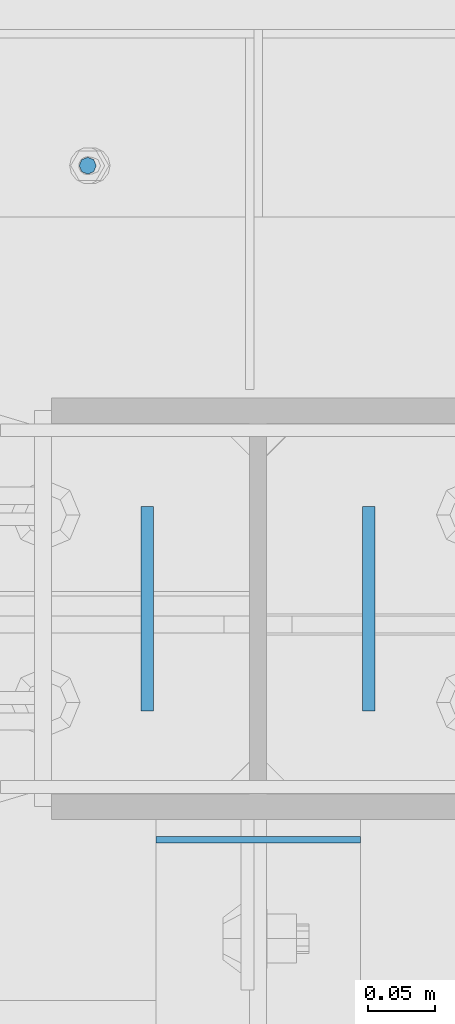
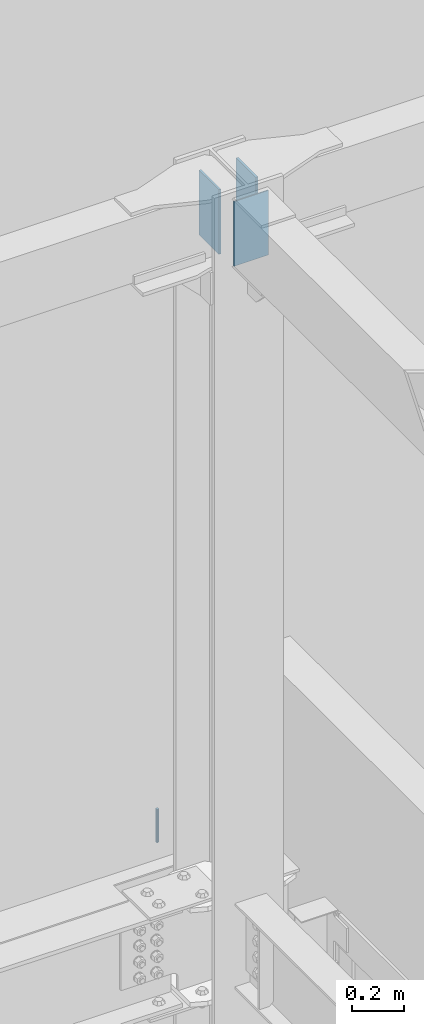
# One storey, part 588 of 1179: 4 columns, 4 elements without a shape of their own.
"""IFC2X3 building model written with IfcOpenShell, lengths in millimetres."""

import ifcopenshell
import ifcopenshell.guid

model = None  # the IFC model being written
_history = None  # IfcOwnerHistory: only IFC2X3 demands one
_inside = {}  # id of a spatial element -> (the spatial element, [elements in it])
_under = {}  # id of a project, library or spatial element -> (it, [spatial elements below it])
_declared = {}  # id of a project -> (the project, [libraries it declares])
_typed = {}  # id of a type object -> (the type object, [elements of that type])
_made_of = {}  # id of a material, layer set ... -> (it, [elements and type objects made of it])


def new_model(schema):
    """Start an empty IFC model of exactly this schema.

    Asked for "IFC4X3", IfcOpenShell would pick the latest addendum, in which some entities
    have other attributes; the version numbers below select the first issue.
    IFC2X3 requires an IfcOwnerHistory on every rooted entity: one is made here for all.
    """
    global model, _history
    if schema == "IFC4X3":
        model = ifcopenshell.file(schema_version=(4, 3, 0, 0))
    else:
        model = ifcopenshell.file(schema=schema)
    _inside.clear()
    _under.clear()
    _declared.clear()
    _typed.clear()
    _made_of.clear()
    _history = None
    if model.schema == "IFC2X3":
        org = make("IfcOrganization", Name="unknown")
        user = make(
            "IfcPersonAndOrganization",
            ThePerson=make("IfcPerson", FamilyName="unknown"),
            TheOrganization=org,
        )
        app = make(
            "IfcApplication",
            ApplicationDeveloper=org,
            Version="unknown",
            ApplicationFullName="unknown",
            ApplicationIdentifier="unknown",
        )
        _history = make(
            "IfcOwnerHistory",
            OwningUser=user,
            OwningApplication=app,
            ChangeAction="ADDED",
            CreationDate=0,
        )
    return model


def make(cls, **values):
    """One entity of the class cls with the attributes given. An attribute that is None is left unset."""
    return model.create_entity(
        cls, **{name: value for name, value in values.items() if value is not None}
    )


def rooted(cls, **values):
    """An entity with a GlobalId (a new one), such as an element, a storey or a relation."""
    return make(cls, GlobalId=ifcopenshell.guid.new(), OwnerHistory=_history, **values)


def si_unit(unit_type, name, prefix=None):
    """IfcSIUnit, for example si_unit("LENGTHUNIT", "METRE", prefix="MILLI")."""
    return make("IfcSIUnit", UnitType=unit_type, Prefix=prefix, Name=name)


def assignment(units):
    """IfcUnitAssignment: the units of a project."""
    return None if units is None else make("IfcUnitAssignment", Units=units)


def point(xyz):
    """IfcCartesianPoint."""
    return None if xyz is None else make("IfcCartesianPoint", Coordinates=xyz)


def direction(xyz):
    """IfcDirection."""
    return None if xyz is None else make("IfcDirection", DirectionRatios=xyz)


def frame(location, z_axis=None, x_axis=None):
    """IfcAxis2Placement3D, a coordinate frame: its origin and axes. An axis left out is left unset."""
    return make(
        "IfcAxis2Placement3D",
        Location=point(location),
        Axis=direction(z_axis),
        RefDirection=direction(x_axis),
    )


def origin_with_axes():
    """The frame at (0, 0, 0) with the z axis (0, 0, 1) and the x axis (1, 0, 0) written out."""
    return frame((0.0, 0.0, 0.0), z_axis=(0.0, 0.0, 1.0), x_axis=(1.0, 0.0, 0.0))


def place(relative_to, where):
    """IfcLocalPlacement: puts the frame where relative to a parent placement (None: the world)."""
    return make(
        "IfcLocalPlacement", PlacementRelTo=relative_to, RelativePlacement=where
    )


def context(
    kind, dimensions, precision=None, world=None, true_north=None, identifier=None
):
    """IfcGeometricRepresentationContext, for example the 3D "Model" context."""
    return make(
        "IfcGeometricRepresentationContext",
        ContextIdentifier=identifier,
        ContextType=kind,
        CoordinateSpaceDimension=dimensions,
        Precision=precision,
        WorldCoordinateSystem=world,
        TrueNorth=true_north,
    )


def subcontext(parent, identifier, kind, view, scale=None):
    """IfcGeometricRepresentationSubContext, for example "Body" below "Model"."""
    return make(
        "IfcGeometricRepresentationSubContext",
        ContextIdentifier=identifier,
        ContextType=kind,
        ParentContext=parent,
        TargetScale=scale,
        TargetView=view,
    )


def project(units=None, contexts=None):
    """IfcProject with its units and contexts."""
    return rooted(
        "IfcProject",
        Name="project",
        RepresentationContexts=contexts,
        UnitsInContext=assignment(units),
    )


def spatial(cls, under=None, at=None, **own):
    """A site, building, storey or space (cls), placed at a placement, below another one or the project."""
    s = rooted(cls, ObjectPlacement=at, **own)
    if under is not None:
        _under.setdefault(under.id(), (under, []))[1].append(s)
    return s


def faces_of(points, faces, orient=None, outer=None):
    """IfcFace entities. A face is a list of loops; a loop is a list of indices into points, from 0.

    orient and outer hold one flag for each loop. By default every Orientation is true, the
    first loop of a face is its IfcFaceOuterBound and the others are IfcFaceBound.
    """
    made = []
    for i, loops in enumerate(faces):
        bounds = []
        for j, loop in enumerate(loops):
            is_outer = j == 0 if outer is None else outer[i][j]
            bounds.append(
                make(
                    "IfcFaceOuterBound" if is_outer else "IfcFaceBound",
                    Bound=make("IfcPolyLoop", Polygon=[points[k] for k in loop]),
                    Orientation=True if orient is None else orient[i][j],
                )
            )
        made.append(make("IfcFace", Bounds=bounds))
    return made


def faceted_brep(points, faces, orient=None, outer=None, voids=None):
    """IfcFacetedBrep: a solid bounded by flat faces; with voids (closed shells), ...WithVoids."""
    shared = [point(p) for p in points]
    hull = make("IfcClosedShell", CfsFaces=faces_of(shared, faces, orient, outer))
    if voids is None:
        return make("IfcFacetedBrep", Outer=hull)
    return make(
        "IfcFacetedBrepWithVoids",
        Outer=hull,
        Voids=[
            make(cls, CfsFaces=faces_of(shared, fs, o, b)) for cls, fs, o, b in voids
        ],
    )


def shape(context_of_items, identifier, shape_type, items):
    """IfcShapeRepresentation: the items that make up one representation, for example the "Body"."""
    return make(
        "IfcShapeRepresentation",
        ContextOfItems=context_of_items,
        RepresentationIdentifier=identifier,
        RepresentationType=shape_type,
        Items=items,
    )


def material(Name=None, Category=None):
    """IfcMaterial."""
    return make("IfcMaterial", Name=Name, Category=Category)


def made_of(thing, what):
    """Note that an element or type object is made of a material, layer set ...; save() writes the relation."""
    if what is not None:
        _made_of.setdefault(what.id(), (what, []))[1].append(thing)
    return thing


def type_object(cls, material=None, **own):
    """A type object (cls), such as IfcWallType, which elements share."""
    return made_of(rooted(cls, **own), material)


def element(
    cls,
    number,
    at=None,
    inside=None,
    cuts=None,
    type_object=None,
    material=None,
    context=None,
    identifier="Body",
    shape_type=None,
    held_by="IfcProductDefinitionShape",
    body=None,
    shapes=None,
    **own,
):
    """One element of the class cls, such as IfcWall. Its Tag is "e" and its number.

    at: its placement. inside: the storey or other place that contains it. cuts: it is an
    opening in that element (IfcRelVoidsElement). A single representation is given by context,
    identifier, shape_type and body (its items); several are given by shapes. held_by: the class
    of the entity that holds the representations. save() writes the other relations.
    """
    e = rooted(cls, Tag="e%d" % number, ObjectPlacement=at, **own)
    if body is not None:
        shapes = [shape(context, identifier, shape_type, body)]
    if shapes is not None:
        e.Representation = make(held_by, Representations=shapes)
    if inside is not None:
        _inside.setdefault(inside.id(), (inside, []))[1].append(e)
    if cuts is not None:
        rooted(
            "IfcRelVoidsElement", RelatingBuildingElement=cuts, RelatedOpeningElement=e
        )
    if type_object is not None:
        _typed.setdefault(type_object.id(), (type_object, []))[1].append(e)
    return made_of(e, material)


def aggregate(whole, parts):
    """IfcRelAggregates: a whole, such as a stair, and the parts it consists of."""
    return rooted("IfcRelAggregates", RelatingObject=whole, RelatedObjects=parts)


def save(model, path):
    """Write the relations noted so far, then the file.

    IfcRelAggregates (storeys below a building ...), IfcRelContainedInSpatialStructure (elements
    in a storey), IfcRelDefinesByType, IfcRelAssociatesMaterial and IfcRelDeclares: one each for
    every whole, place, type object, material and project.
    """
    for whole, parts in _under.values():
        aggregate(whole, parts)
    for where, things in _inside.values():
        rooted(
            "IfcRelContainedInSpatialStructure",
            RelatedElements=things,
            RelatingStructure=where,
        )
    for kind, things in _typed.values():
        rooted("IfcRelDefinesByType", RelatedObjects=things, RelatingType=kind)
    for what, things in _made_of.values():
        rooted("IfcRelAssociatesMaterial", RelatedObjects=things, RelatingMaterial=what)
    for by, libraries in _declared.values():
        rooted("IfcRelDeclares", RelatingContext=by, RelatedDefinitions=libraries)
    model.write(path)


model = new_model("IFC2X3")

# Units and contexts
model_context = context("Model", 3, precision=1e-05, world=origin_with_axes())
body_context = subcontext(model_context, "Body", "Model", "MODEL_VIEW")
ifc_project = project(units=[si_unit("LENGTHUNIT", "METRE", prefix="MILLI"), si_unit("AREAUNIT", "SQUARE_METRE"), si_unit("VOLUMEUNIT", "CUBIC_METRE"), si_unit("MASSUNIT", "GRAM", prefix="KILO"), si_unit("TIMEUNIT", "SECOND"), si_unit("PLANEANGLEUNIT", "RADIAN"), si_unit("SOLIDANGLEUNIT", "STERADIAN"), si_unit("THERMODYNAMICTEMPERATUREUNIT", "DEGREE_CELSIUS"), si_unit("LUMINOUSINTENSITYUNIT", "LUMEN")], contexts=[model_context])

# Site, building, storey
site_placement = place(None, origin_with_axes())
site = spatial("IfcSite", under=ifc_project, at=site_placement, CompositionType="ELEMENT")
building_placement = place(site_placement, origin_with_axes())
building = spatial("IfcBuilding", under=site, at=building_placement, Name="Undefined", CompositionType="ELEMENT")
storey_placement = place(building_placement, origin_with_axes())
storey = spatial("IfcBuildingStorey", under=building, at=storey_placement, Name="Undefined", CompositionType="ELEMENT", Elevation=0.0)

# Assembly, column
assembly_1_placement = place(storey_placement, origin_with_axes())
assembly_1 = element("IfcElementAssembly", 1, at=assembly_1_placement, inside=storey, Name="BEAM", AssemblyPlace="NOTDEFINED", PredefinedType="RIGID_FRAME")
ifc_material_1 = material(Name="STEEL/A307")
column_type_1 = type_object("IfcColumnType", PredefinedType="NOTDEFINED")
column_1_placement = place(assembly_1_placement, frame((16332.2, 41529.0, 13125.45), z_axis=(0.0, 1.0, 0.0), x_axis=(0.0, 0.0, 1.0)))
column_1 = element("IfcColumn", 2, at=column_1_placement, type_object=column_type_1, material=ifc_material_1, Name="THREADED ROD", context=body_context, shape_type="Brep", body=[
    faceted_brep([(0.0, -6.34999999999854, 0.0), (0.0, -4.49012806053361, -4.49012806053452), (157.162499999999, -4.49012806053361, -4.49012806053361), (157.162499999999, -6.34999999999854, 0.0), (0.0, 0.0, -6.34999999999991), (157.162499999999, 0.0, -6.34999999999854), (0.0, 4.49012806053361, -4.49012806053452), (157.162499999999, 4.49012806053361, -4.49012806053361), (0.0, 6.34999999999854, 0.0), (157.162499999999, 6.34999999999854, 0.0), (0.0, 4.49012806053361, 4.49012806053452), (157.162499999999, 4.49012806053361, 4.49012806053361), (0.0, 0.0, 6.34999999999991), (157.162499999999, 0.0, 6.34999999999854), (0.0, -4.49012806053361, 4.49012806053452), (157.162499999999, -4.49012806053361, 4.49012806053361)], [[[0, 1, 2, 3]], [[1, 4, 5, 2]], [[4, 6, 7, 5]], [[6, 8, 9, 7]], [[8, 10, 11, 9]], [[10, 12, 13, 11]], [[12, 14, 15, 13]], [[14, 0, 3, 15]], [[5, 7, 9, 11, 13, 15, 3, 2]], [[14, 12, 10, 8, 6, 4, 1, 0]]]),
])
aggregate(assembly_1, [column_1])

assembly_2_placement = place(storey_placement, origin_with_axes())
assembly_2 = element("IfcElementAssembly", 3, at=assembly_2_placement, inside=storey, Name="BEAM", AssemblyPlace="NOTDEFINED", PredefinedType="RIGID_FRAME")
ifc_material_2 = material(Name="STEEL/A36")
column_type_2 = type_object("IfcColumnType", PredefinedType="NOTDEFINED")
column_2_placement = place(assembly_2_placement, frame((16376.6499999594, 41198.8, 16122.65), z_axis=(0.0, 1.0, 0.0), x_axis=(0.0, 0.0, 1.0)))
column_2 = element("IfcColumn", 4, at=column_2_placement, type_object=column_type_2, material=ifc_material_2, Name="PLATE", context=body_context, shape_type="Brep", body=[
    faceted_brep([(0.0, 4.76249999999982, -76.1999999999971), (0.0, 4.76249999999982, 76.1999999999971), (304.799999999999, 4.76250000000073, 76.1999999999971), (304.799999999999, 4.76250000000073, -76.1999999999971), (0.0, -4.76249999999982, 76.1999999999971), (304.799999999999, -4.76250000000073, 76.1999999999971), (0.0, -4.76249999999982, -76.1999999999971), (304.799999999999, -4.76250000000073, -76.1999999999971)], [[[0, 1, 2, 3]], [[1, 4, 5, 2]], [[4, 6, 7, 5]], [[6, 0, 3, 7]], [[5, 7, 3, 2]], [[6, 4, 1, 0]]]),
])
aggregate(assembly_2, [column_2])

assembly_3_placement = place(storey_placement, origin_with_axes())
assembly_3 = element("IfcElementAssembly", 5, at=assembly_3_placement, inside=storey, Name="BEAM", AssemblyPlace="NOTDEFINED", PredefinedType="RIGID_FRAME")
column_3_placement = place(assembly_3_placement, frame((16541.75, 41198.8, 16122.65), z_axis=(0.0, -1.0, 0.0), x_axis=(0.0, 0.0, 1.0)))
column_3 = element("IfcColumn", 6, at=column_3_placement, type_object=column_type_2, material=ifc_material_2, Name="PLATE", context=body_context, shape_type="Brep", body=[
    faceted_brep([(0.0, 4.76249999999982, -76.1999999999971), (0.0, 4.76249999999982, 76.1999999999971), (304.799999999999, 4.76250000000073, 76.1999999999971), (304.799999999999, 4.76250000000073, -76.1999999999971), (0.0, -4.76249999999982, 76.1999999999971), (304.799999999999, -4.76250000000073, 76.1999999999971), (0.0, -4.76249999999982, -76.1999999999971), (304.799999999999, -4.76250000000073, -76.1999999999971)], [[[0, 1, 2, 3]], [[1, 4, 5, 2]], [[4, 6, 7, 5]], [[6, 0, 3, 7]], [[5, 7, 3, 2]], [[6, 4, 1, 0]]]),
])
aggregate(assembly_3, [column_3])

assembly_4_placement = place(storey_placement, origin_with_axes())
assembly_4 = element("IfcElementAssembly", 7, at=assembly_4_placement, inside=storey, Name="BEAM", AssemblyPlace="NOTDEFINED", PredefinedType="RIGID_FRAME")
column_type_3 = type_object("IfcColumnType", PredefinedType="NOTDEFINED")
column_4_placement = place(assembly_4_placement, frame((16459.2, 41026.5565, 16122.65), z_axis=(-1.0, 0.0, 0.0), x_axis=(0.0, 0.0, 1.0)))
column_4 = element("IfcColumn", 8, at=column_4_placement, type_object=column_type_3, material=ifc_material_2, Name="PLATE", context=body_context, shape_type="Brep", body=[
    faceted_brep([(0.0, 2.38150000000041, -76.1999999999998), (0.0, 2.38150000000041, 76.1999999999998), (304.799999999999, 2.38150000000314, 76.2), (304.799999999999, 2.38150000000314, -76.2), (0.0, -2.38150000000041, 76.1999999999998), (304.799999999999, -2.38150000000314, 76.2), (0.0, -2.38150000000041, -76.1999999999998), (304.799999999999, -2.38150000000314, -76.2)], [[[0, 1, 2, 3]], [[1, 4, 5, 2]], [[4, 6, 7, 5]], [[6, 0, 3, 7]], [[5, 7, 3, 2]], [[6, 4, 1, 0]]]),
])
aggregate(assembly_4, [column_4])

save(model, "model.ifc")
